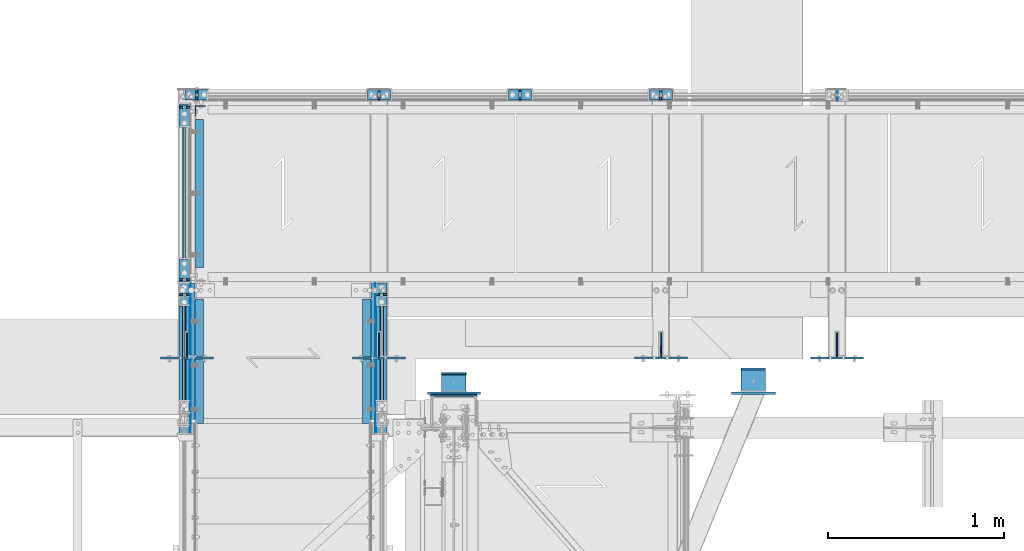
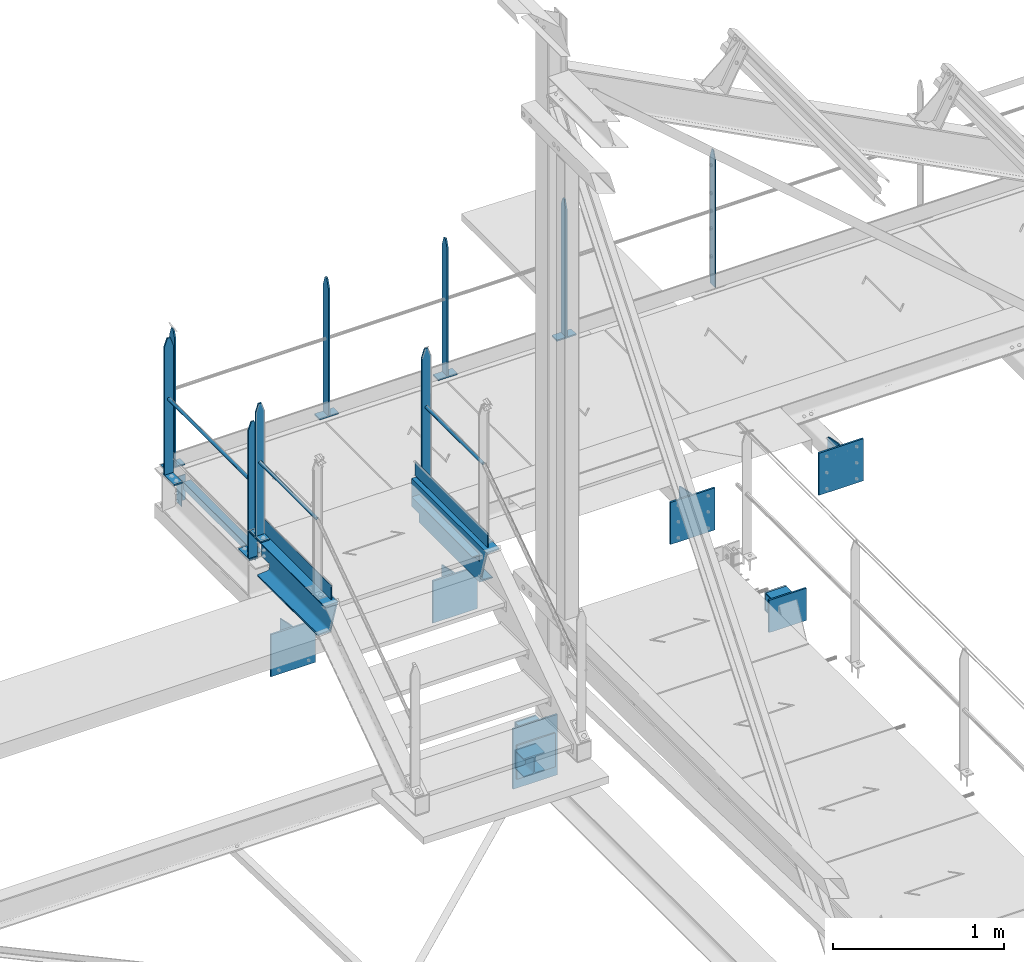
# One storey, part 95 of 496: 45 beams, 18 elements without a shape of their own.
"""IFC2X3 building model written with IfcOpenShell, lengths in millimetres."""

import ifcopenshell
import ifcopenshell.guid

model = None  # the IFC model being written
_history = None  # IfcOwnerHistory: only IFC2X3 demands one
_inside = {}  # id of a spatial element -> (the spatial element, [elements in it])
_under = {}  # id of a project, library or spatial element -> (it, [spatial elements below it])
_declared = {}  # id of a project -> (the project, [libraries it declares])
_typed = {}  # id of a type object -> (the type object, [elements of that type])
_made_of = {}  # id of a material, layer set ... -> (it, [elements and type objects made of it])


def new_model(schema):
    """Start an empty IFC model of exactly this schema.

    Asked for "IFC4X3", IfcOpenShell would pick the latest addendum, in which some entities
    have other attributes; the version numbers below select the first issue.
    IFC2X3 requires an IfcOwnerHistory on every rooted entity: one is made here for all.
    """
    global model, _history
    if schema == "IFC4X3":
        model = ifcopenshell.file(schema_version=(4, 3, 0, 0))
    else:
        model = ifcopenshell.file(schema=schema)
    _inside.clear()
    _under.clear()
    _declared.clear()
    _typed.clear()
    _made_of.clear()
    _history = None
    if model.schema == "IFC2X3":
        org = make("IfcOrganization", Name="unknown")
        user = make(
            "IfcPersonAndOrganization",
            ThePerson=make("IfcPerson", FamilyName="unknown"),
            TheOrganization=org,
        )
        app = make(
            "IfcApplication",
            ApplicationDeveloper=org,
            Version="unknown",
            ApplicationFullName="unknown",
            ApplicationIdentifier="unknown",
        )
        _history = make(
            "IfcOwnerHistory",
            OwningUser=user,
            OwningApplication=app,
            ChangeAction="ADDED",
            CreationDate=0,
        )
    return model


def make(cls, **values):
    """One entity of the class cls with the attributes given. An attribute that is None is left unset."""
    return model.create_entity(
        cls, **{name: value for name, value in values.items() if value is not None}
    )


def rooted(cls, **values):
    """An entity with a GlobalId (a new one), such as an element, a storey or a relation."""
    return make(cls, GlobalId=ifcopenshell.guid.new(), OwnerHistory=_history, **values)


def si_unit(unit_type, name, prefix=None):
    """IfcSIUnit, for example si_unit("LENGTHUNIT", "METRE", prefix="MILLI")."""
    return make("IfcSIUnit", UnitType=unit_type, Prefix=prefix, Name=name)


def assignment(units):
    """IfcUnitAssignment: the units of a project."""
    return None if units is None else make("IfcUnitAssignment", Units=units)


def point(xyz):
    """IfcCartesianPoint."""
    return None if xyz is None else make("IfcCartesianPoint", Coordinates=xyz)


def direction(xyz):
    """IfcDirection."""
    return None if xyz is None else make("IfcDirection", DirectionRatios=xyz)


def frame(location, z_axis=None, x_axis=None):
    """IfcAxis2Placement3D, a coordinate frame: its origin and axes. An axis left out is left unset."""
    return make(
        "IfcAxis2Placement3D",
        Location=point(location),
        Axis=direction(z_axis),
        RefDirection=direction(x_axis),
    )


def frame_2d(location, x_axis=None):
    """IfcAxis2Placement2D, a coordinate frame in the plane: its origin and x axis."""
    return make(
        "IfcAxis2Placement2D", Location=point(location), RefDirection=direction(x_axis)
    )


def origin_with_axes():
    """The frame at (0, 0, 0) with the z axis (0, 0, 1) and the x axis (1, 0, 0) written out."""
    return frame((0.0, 0.0, 0.0), z_axis=(0.0, 0.0, 1.0), x_axis=(1.0, 0.0, 0.0))


def origin_2d_with_axis():
    """The frame at (0, 0) in the plane with the x axis (1, 0) written out."""
    return frame_2d((0.0, 0.0), x_axis=(1.0, 0.0))


def place(relative_to, where):
    """IfcLocalPlacement: puts the frame where relative to a parent placement (None: the world)."""
    return make(
        "IfcLocalPlacement", PlacementRelTo=relative_to, RelativePlacement=where
    )


def context(
    kind, dimensions, precision=None, world=None, true_north=None, identifier=None
):
    """IfcGeometricRepresentationContext, for example the 3D "Model" context."""
    return make(
        "IfcGeometricRepresentationContext",
        ContextIdentifier=identifier,
        ContextType=kind,
        CoordinateSpaceDimension=dimensions,
        Precision=precision,
        WorldCoordinateSystem=world,
        TrueNorth=true_north,
    )


def subcontext(parent, identifier, kind, view, scale=None):
    """IfcGeometricRepresentationSubContext, for example "Body" below "Model"."""
    return make(
        "IfcGeometricRepresentationSubContext",
        ContextIdentifier=identifier,
        ContextType=kind,
        ParentContext=parent,
        TargetScale=scale,
        TargetView=view,
    )


def project(units=None, contexts=None):
    """IfcProject with its units and contexts."""
    return rooted(
        "IfcProject",
        Name="project",
        RepresentationContexts=contexts,
        UnitsInContext=assignment(units),
    )


def spatial(cls, under=None, at=None, **own):
    """A site, building, storey or space (cls), placed at a placement, below another one or the project."""
    s = rooted(cls, ObjectPlacement=at, **own)
    if under is not None:
        _under.setdefault(under.id(), (under, []))[1].append(s)
    return s


def polyline(points):
    """IfcPolyline through the points."""
    return make("IfcPolyline", Points=[point(p) for p in points])


def profile(cls, at=None, kind="AREA", **sizes):
    """A parametric profile (cls). Its sizes go by their IFC names, for example OverallWidth=200.0."""
    return make(cls, ProfileType=kind, Position=at, **sizes)


def rectangle(**sizes):
    """IfcRectangleProfileDef."""
    return profile("IfcRectangleProfileDef", **sizes)


def hollow_circle(**sizes):
    """IfcCircleHollowProfileDef."""
    return profile("IfcCircleHollowProfileDef", **sizes)


def i_section(**sizes):
    """IfcIShapeProfileDef."""
    return profile("IfcIShapeProfileDef", **sizes)


def l_section(**sizes):
    """IfcLShapeProfileDef."""
    return profile("IfcLShapeProfileDef", **sizes)


def u_section(**sizes):
    """IfcUShapeProfileDef."""
    return profile("IfcUShapeProfileDef", **sizes)


def outline(outer, holes=None, kind="AREA"):
    """IfcArbitraryClosedProfileDef: a profile drawn as a closed curve; with holes, ...WithVoids."""
    if holes is None:
        return make("IfcArbitraryClosedProfileDef", ProfileType=kind, OuterCurve=outer)
    return make(
        "IfcArbitraryProfileDefWithVoids",
        ProfileType=kind,
        OuterCurve=outer,
        InnerCurves=holes,
    )


def extrude(swept, where, along, depth):
    """IfcExtrudedAreaSolid: the profile swept, set in the frame where, extruded along a direction by depth."""
    return make(
        "IfcExtrudedAreaSolid",
        SweptArea=swept,
        Position=where,
        ExtrudedDirection=direction(along),
        Depth=depth,
    )


def boolean(op, a, b):
    """IfcBooleanResult of two solids."""
    return make("IfcBooleanResult", Operator=op, FirstOperand=a, SecondOperand=b)


def clip(a, b, op="DIFFERENCE"):
    """IfcBooleanClippingResult: the solid a cut by the half space b."""
    return make(
        "IfcBooleanClippingResult", Operator=op, FirstOperand=a, SecondOperand=b
    )


def halfspace(plane, agree):
    """IfcHalfSpaceSolid: all space on one side of the plane z = 0 of the frame plane."""
    return make(
        "IfcHalfSpaceSolid",
        BaseSurface=make("IfcPlane", Position=plane),
        AgreementFlag=agree,
    )


def shape(context_of_items, identifier, shape_type, items):
    """IfcShapeRepresentation: the items that make up one representation, for example the "Body"."""
    return make(
        "IfcShapeRepresentation",
        ContextOfItems=context_of_items,
        RepresentationIdentifier=identifier,
        RepresentationType=shape_type,
        Items=items,
    )


def material(Name=None, Category=None):
    """IfcMaterial."""
    return make("IfcMaterial", Name=Name, Category=Category)


def made_of(thing, what):
    """Note that an element or type object is made of a material, layer set ...; save() writes the relation."""
    if what is not None:
        _made_of.setdefault(what.id(), (what, []))[1].append(thing)
    return thing


def type_object(cls, material=None, **own):
    """A type object (cls), such as IfcWallType, which elements share."""
    return made_of(rooted(cls, **own), material)


def element(
    cls,
    number,
    at=None,
    inside=None,
    cuts=None,
    type_object=None,
    material=None,
    context=None,
    identifier="Body",
    shape_type=None,
    held_by="IfcProductDefinitionShape",
    body=None,
    shapes=None,
    **own,
):
    """One element of the class cls, such as IfcWall. Its Tag is "e" and its number.

    at: its placement. inside: the storey or other place that contains it. cuts: it is an
    opening in that element (IfcRelVoidsElement). A single representation is given by context,
    identifier, shape_type and body (its items); several are given by shapes. held_by: the class
    of the entity that holds the representations. save() writes the other relations.
    """
    e = rooted(cls, Tag="e%d" % number, ObjectPlacement=at, **own)
    if body is not None:
        shapes = [shape(context, identifier, shape_type, body)]
    if shapes is not None:
        e.Representation = make(held_by, Representations=shapes)
    if inside is not None:
        _inside.setdefault(inside.id(), (inside, []))[1].append(e)
    if cuts is not None:
        rooted(
            "IfcRelVoidsElement", RelatingBuildingElement=cuts, RelatedOpeningElement=e
        )
    if type_object is not None:
        _typed.setdefault(type_object.id(), (type_object, []))[1].append(e)
    return made_of(e, material)


def aggregate(whole, parts):
    """IfcRelAggregates: a whole, such as a stair, and the parts it consists of."""
    return rooted("IfcRelAggregates", RelatingObject=whole, RelatedObjects=parts)


def save(model, path):
    """Write the relations noted so far, then the file.

    IfcRelAggregates (storeys below a building ...), IfcRelContainedInSpatialStructure (elements
    in a storey), IfcRelDefinesByType, IfcRelAssociatesMaterial and IfcRelDeclares: one each for
    every whole, place, type object, material and project.
    """
    for whole, parts in _under.values():
        aggregate(whole, parts)
    for where, things in _inside.values():
        rooted(
            "IfcRelContainedInSpatialStructure",
            RelatedElements=things,
            RelatingStructure=where,
        )
    for kind, things in _typed.values():
        rooted("IfcRelDefinesByType", RelatedObjects=things, RelatingType=kind)
    for what, things in _made_of.values():
        rooted("IfcRelAssociatesMaterial", RelatedObjects=things, RelatingMaterial=what)
    for by, libraries in _declared.values():
        rooted("IfcRelDeclares", RelatingContext=by, RelatedDefinitions=libraries)
    model.write(path)


model = new_model("IFC2X3")

# Units and contexts
model_context = context("Model", 3, precision=1e-05, world=origin_with_axes())
body_context = subcontext(model_context, "Body", "Model", "MODEL_VIEW")
ifc_project = project(units=[si_unit("LENGTHUNIT", "METRE", prefix="MILLI"), si_unit("AREAUNIT", "SQUARE_METRE"), si_unit("VOLUMEUNIT", "CUBIC_METRE"), si_unit("MASSUNIT", "GRAM", prefix="KILO"), si_unit("TIMEUNIT", "SECOND"), si_unit("PLANEANGLEUNIT", "RADIAN"), si_unit("SOLIDANGLEUNIT", "STERADIAN"), si_unit("THERMODYNAMICTEMPERATUREUNIT", "DEGREE_CELSIUS"), si_unit("LUMINOUSINTENSITYUNIT", "LUMEN")], contexts=[model_context])

# Site, building, storey
site_placement = place(None, origin_with_axes())
site = spatial("IfcSite", under=ifc_project, at=site_placement, CompositionType="ELEMENT")
building_placement = place(site_placement, origin_with_axes())
building = spatial("IfcBuilding", under=site, at=building_placement, Name="Undefined", CompositionType="ELEMENT")
storey_placement = place(building_placement, origin_with_axes())
storey = spatial("IfcBuildingStorey", under=building, at=storey_placement, Name="Undefined", CompositionType="ELEMENT", Elevation=0.0)

# Assembly, beams
assembly_1_placement = place(storey_placement, origin_with_axes())
assembly_1 = element("IfcElementAssembly", 1, at=assembly_1_placement, inside=storey, Name="MAIN COURANTE", AssemblyPlace="NOTDEFINED", PredefinedType="NOTDEFINED")
ifc_material_1 = material(Name="Undefined/S235-E24")
beam_type_1 = type_object("IfcBeamType", PredefinedType="NOTDEFINED")
beam_1_placement = place(assembly_1_placement, frame((13119.9961849193, 17089.9938659712, 8705.00000001012), z_axis=(0.0, 1.0, 0.0), x_axis=(-1.0, 0.0, 0.0)))
beam_1 = element("IfcBeam", 2, at=beam_1_placement, type_object=beam_type_1, material=ifc_material_1, context=body_context, shape_type="SweptSolid", body=[
    extrude(rectangle(XDim=10.0, YDim=60.0, at=origin_2d_with_axis()), frame((130.0, 0.0, 0.0), z_axis=(-1.0, 0.0, 0.0), x_axis=(0.0, -1.0, 0.0)), (0.0, 0.0, 1.0), 130.0),
])
beam_2_placement = place(assembly_1_placement, frame((13054.9961849193, 17089.9938659712, 9677.59999847), z_axis=(0.0, -1.0, 0.0), x_axis=(0.0, 0.0, -1.0)))
beam_2 = element("IfcBeam", 3, at=beam_2_placement, type_object=beam_type_1, material=ifc_material_1, Name="MONTANT", context=body_context, shape_type="Clipping", body=[
    clip(clip(extrude(rectangle(XDim=10.0, YDim=60.0, at=origin_2d_with_axis()), frame((967.59999845988, 0.0, 0.0), z_axis=(-1.0, 0.0, 0.0), x_axis=(0.0, -1.0, 0.0)), (0.0, 0.0, 1.0), 967.6), halfspace(frame((-120.0, 5.0, -30.0), z_axis=(-0.316227766016838, 0.0, 0.948683298050514), x_axis=(0.948683298050514, 0.0, 0.316227766016838)), False)), halfspace(frame((60.0, 5.0, -30.0), z_axis=(-0.316227766016838, 0.0, -0.948683298050514), x_axis=(-0.948683298050514, 0.0, 0.316227766016838)), False)),
])
beam_3_placement = place(assembly_1_placement, frame((13919.9961849193, 17089.9938659712, 8705.00000001012), z_axis=(0.0, 1.0, 0.0), x_axis=(-1.0, 0.0, 0.0)))
beam_3 = element("IfcBeam", 4, at=beam_3_placement, type_object=beam_type_1, material=ifc_material_1, context=body_context, shape_type="SweptSolid", body=[
    extrude(rectangle(XDim=10.0, YDim=60.0, at=origin_2d_with_axis()), frame((130.0, 0.0, 0.0), z_axis=(-1.0, 0.0, 0.0), x_axis=(0.0, -1.0, 0.0)), (0.0, 0.0, 1.0), 130.0),
])
beam_4_placement = place(assembly_1_placement, frame((11285.0061849211, 17089.9938659712, 8705.00001258772), z_axis=(0.0, 1.0, 0.0), x_axis=(-1.0, 0.0, 0.0)))
beam_4 = element("IfcBeam", 5, at=beam_4_placement, type_object=beam_type_1, material=ifc_material_1, context=body_context, shape_type="SweptSolid", body=[
    extrude(rectangle(XDim=10.0, YDim=60.0, at=origin_2d_with_axis()), frame((130.0, 0.0, 0.0), z_axis=(-1.0, 0.0, 0.0), x_axis=(0.0, -1.0, 0.0)), (0.0, 0.0, 1.0), 130.0),
])
beam_5_placement = place(assembly_1_placement, frame((11220.0061849211, 17089.9938659712, 9677.6000110476), z_axis=(0.0, -1.0, 0.0), x_axis=(0.0, 0.0, -1.0)))
beam_5 = element("IfcBeam", 6, at=beam_5_placement, type_object=beam_type_1, material=ifc_material_1, Name="MONTANT", context=body_context, shape_type="Clipping", body=[
    clip(clip(extrude(rectangle(XDim=10.0, YDim=60.0, at=origin_2d_with_axis()), frame((967.59999845988, 0.0, 0.0), z_axis=(-1.0, 0.0, 0.0), x_axis=(0.0, -1.0, 0.0)), (0.0, 0.0, 1.0), 967.6), halfspace(frame((-120.0, 5.0, -30.0), z_axis=(-0.316227766016838, 0.0, 0.948683298050514), x_axis=(0.948683298050514, 0.0, 0.316227766016838)), False)), halfspace(frame((60.0, 5.0, -30.0), z_axis=(-0.316227766016838, 0.0, -0.948683298050514), x_axis=(-0.948683298050514, 0.0, 0.316227766016838)), False)),
])
beam_6_placement = place(assembly_1_placement, frame((12319.9961849193, 17089.9938659712, 8705.00000001012), z_axis=(0.0, 1.0, 0.0), x_axis=(-1.0, 0.0, 0.0)))
beam_6 = element("IfcBeam", 7, at=beam_6_placement, type_object=beam_type_1, material=ifc_material_1, context=body_context, shape_type="SweptSolid", body=[
    extrude(rectangle(XDim=10.0, YDim=60.0, at=origin_2d_with_axis()), frame((130.0, 0.0, 0.0), z_axis=(-1.0, 0.0, 0.0), x_axis=(0.0, -1.0, 0.0)), (0.0, 0.0, 1.0), 130.0),
])

assembly_2_placement = place(storey_placement, origin_with_axes())
assembly_2 = element("IfcElementAssembly", 8, at=assembly_2_placement, inside=storey, Name="MAIN COURANTE", AssemblyPlace="NOTDEFINED", PredefinedType="NOTDEFINED")
beam_7_placement = place(assembly_2_placement, frame((11149.9863365012, 16155.0036560214, 8705.00000001012), z_axis=(-1.0, 0.0, 0.0), x_axis=(0.0, -1.0, 0.0)))
beam_7 = element("IfcBeam", 9, at=beam_7_placement, type_object=beam_type_1, material=ifc_material_1, context=body_context, shape_type="SweptSolid", body=[
    extrude(rectangle(XDim=10.0, YDim=60.0, at=origin_2d_with_axis()), frame((130.0, 0.0, 0.0), z_axis=(-1.0, 0.0, 0.0), x_axis=(0.0, -1.0, 0.0)), (0.0, 0.0, 1.0), 130.0),
])
beam_8_placement = place(assembly_2_placement, frame((11149.9862112009, 16040.0036560214, 9677.59999848012), z_axis=(-0.99999999999782, -2.08799998896818e-06, 0.0), x_axis=(0.0, 0.0, -1.0)))
beam_8 = element("IfcBeam", 10, at=beam_8_placement, type_object=beam_type_1, material=ifc_material_1, Name="MONTANT", context=body_context, shape_type="Clipping", body=[
    clip(clip(extrude(rectangle(XDim=10.0, YDim=60.0, at=origin_2d_with_axis()), frame((967.59999845988, 0.0, 0.0), z_axis=(-1.0, 0.0, 0.0), x_axis=(0.0, -1.0, 0.0)), (0.0, 0.0, 1.0), 967.6), halfspace(frame((-119.999937359999, -4.99999999999636, -30.0), z_axis=(-0.316227766016837, -1.98085072276202e-06, 0.948683298048446), x_axis=(-6.26399999950979e-06, 0.999999999980381, -3.63797880701241e-15)), False)), halfspace(frame((60.0, -5.0, -30.0), z_axis=(-0.316227469016822, 1.98084886235393e-06, -0.948683397048399), x_axis=(6.26399999950979e-06, 0.999999999980381, -3.63797880701241e-15)), False)),
])
beam_9_placement = place(assembly_2_placement, frame((11149.9863365012, 17034.9977309424, 8705.00000001012), z_axis=(-1.0, 0.0, 0.0), x_axis=(0.0, -1.0, 0.0)))
beam_9 = element("IfcBeam", 11, at=beam_9_placement, type_object=beam_type_1, material=ifc_material_1, context=body_context, shape_type="SweptSolid", body=[
    extrude(rectangle(XDim=10.0, YDim=60.0, at=origin_2d_with_axis()), frame((130.0, 0.0, 0.0), z_axis=(-1.0, 0.0, 0.0), x_axis=(0.0, -1.0, 0.0)), (0.0, 0.0, 1.0), 130.0),
])
beam_10_placement = place(assembly_2_placement, frame((11149.9862112009, 17019.9977309424, 9677.59999848012), z_axis=(-0.99999999999782, -2.08799998896818e-06, 0.0), x_axis=(0.0, 0.0, -1.0)))
beam_10 = element("IfcBeam", 12, at=beam_10_placement, type_object=beam_type_1, material=ifc_material_1, Name="MONTANT", context=body_context, shape_type="Clipping", body=[
    clip(clip(extrude(rectangle(XDim=10.0, YDim=60.0, at=origin_2d_with_axis()), frame((967.59999845988, 0.0, 0.0), z_axis=(-1.0, 0.0, 0.0), x_axis=(0.0, -1.0, 0.0)), (0.0, 0.0, 1.0), 967.6), halfspace(frame((-119.999937359999, -4.99999999999636, -30.0), z_axis=(-0.316227766016837, -1.98085072276202e-06, 0.948683298048446), x_axis=(-6.26399999950979e-06, 0.999999999980381, -3.63797880701241e-15)), False)), halfspace(frame((60.0, -5.0, -30.0), z_axis=(-0.316227469016822, 1.98084886235393e-06, -0.948683397048399), x_axis=(6.26399999950979e-06, 0.999999999980381, -3.63797880701241e-15)), False)),
])

# Beam
beam_11_placement = place(assembly_1_placement, frame((13854.9961849193, 17089.9938659712, 9677.59999847), z_axis=(0.0, -1.0, 0.0), x_axis=(0.0, 0.0, -1.0)))
beam_11 = element("IfcBeam", 13, at=beam_11_placement, type_object=beam_type_1, material=ifc_material_1, Name="MONTANT", context=body_context, shape_type="Clipping", body=[
    clip(clip(extrude(rectangle(XDim=10.0, YDim=60.0, at=origin_2d_with_axis()), frame((967.59999845988, 0.0, 0.0), z_axis=(-1.0, 0.0, 0.0), x_axis=(0.0, -1.0, 0.0)), (0.0, 0.0, 1.0), 967.6), halfspace(frame((-120.0, 5.0, -30.0), z_axis=(-0.316227766016838, 0.0, 0.948683298050514), x_axis=(0.948683298050514, 0.0, 0.316227766016838)), False)), halfspace(frame((60.0, 5.0, -30.0), z_axis=(-0.316227766016838, 0.0, -0.948683298050514), x_axis=(-0.948683298050514, 0.0, 0.316227766016838)), False)),
])

beam_12_placement = place(assembly_1_placement, frame((12254.9961849193, 17089.9938659712, 9677.59999847), z_axis=(0.0, -1.0, 0.0), x_axis=(0.0, 0.0, -1.0)))
beam_12 = element("IfcBeam", 14, at=beam_12_placement, type_object=beam_type_1, material=ifc_material_1, Name="MONTANT", context=body_context, shape_type="Clipping", body=[
    clip(clip(extrude(rectangle(XDim=10.0, YDim=60.0, at=origin_2d_with_axis()), frame((967.59999845988, 0.0, 0.0), z_axis=(-1.0, 0.0, 0.0), x_axis=(0.0, -1.0, 0.0)), (0.0, 0.0, 1.0), 967.6), halfspace(frame((-120.0, 5.0, -30.0), z_axis=(-0.316227766016838, 0.0, 0.948683298050514), x_axis=(0.948683298050514, 0.0, 0.316227766016838)), False)), halfspace(frame((60.0, 5.0, -30.0), z_axis=(-0.316227766016838, 0.0, -0.948683298050514), x_axis=(-0.948683298050514, 0.0, 0.316227766016838)), False)),
])

aggregate(assembly_1, [beam_1, beam_2, beam_3, beam_4, beam_5, beam_6, beam_11, beam_12])

# Assembly, beams
assembly_3_placement = place(storey_placement, origin_with_axes())
assembly_3 = element("IfcElementAssembly", 15, at=assembly_3_placement, inside=storey, Name="MAIN COURANTE", AssemblyPlace="NOTDEFINED", PredefinedType="NOTDEFINED")
beam_13_placement = place(assembly_3_placement, frame((11149.9863365012, 16019.9996531834, 8915.0), z_axis=(-1.0, 0.0, 0.0), x_axis=(0.0, -1.0, 0.0)))
beam_13 = element("IfcBeam", 16, at=beam_13_placement, type_object=beam_type_1, material=ifc_material_1, context=body_context, shape_type="SweptSolid", body=[
    extrude(rectangle(XDim=10.0, YDim=60.0, at=origin_2d_with_axis()), frame((130.0, 0.0, 0.0), z_axis=(-1.0, 0.0, 0.0), x_axis=(0.0, -1.0, 0.0)), (0.0, 0.0, 1.0), 130.0),
])
beam_14_placement = place(assembly_3_placement, frame((11149.9862112009, 15954.9996531834, 9857.59999847), z_axis=(-0.99999999999782, -2.08799998896818e-06, 0.0), x_axis=(0.0, 0.0, -1.0)))
beam_14 = element("IfcBeam", 17, at=beam_14_placement, type_object=beam_type_1, material=ifc_material_1, Name="MONTANT", context=body_context, shape_type="Clipping", body=[
    clip(clip(extrude(rectangle(XDim=10.0, YDim=60.0, at=origin_2d_with_axis()), frame((937.599998469999, 0.0, 0.0), z_axis=(-1.0, 0.0, 0.0), x_axis=(0.0, -1.0, 0.0)), (0.0, 0.0, 1.0), 937.6), halfspace(frame((-119.999937359999, -4.99999999999636, -30.0), z_axis=(-0.316227766016837, -1.98085072276202e-06, 0.948683298048446), x_axis=(-6.26399999950979e-06, 0.999999999980381, -3.63797880701241e-15)), False)), halfspace(frame((60.0, -5.0, -30.0), z_axis=(-0.316227469016822, 1.98084886235393e-06, -0.948683397048399), x_axis=(6.26399999950979e-06, 0.999999999980381, -3.63797880701241e-15)), False)),
])

assembly_4_placement = place(storey_placement, origin_with_axes())
assembly_4 = element("IfcElementAssembly", 18, at=assembly_4_placement, inside=storey, Name="MAIN COURANTE", AssemblyPlace="NOTDEFINED", PredefinedType="NOTDEFINED")
beam_15_placement = place(assembly_4_placement, frame((12269.9936634988, 16019.9996531834, 8915.0), z_axis=(1.0, 0.0, 0.0), x_axis=(0.0, -1.0, 0.0)))
beam_15 = element("IfcBeam", 19, at=beam_15_placement, type_object=beam_type_1, material=ifc_material_1, context=body_context, shape_type="SweptSolid", body=[
    extrude(rectangle(XDim=10.0, YDim=60.0, at=origin_2d_with_axis()), frame((130.0, 0.0, 0.0), z_axis=(-1.0, 0.0, 0.0), x_axis=(0.0, -1.0, 0.0)), (0.0, 0.0, 1.0), 130.0),
])
beam_16_placement = place(assembly_4_placement, frame((12269.9937887991, 15954.9996531834, 9857.59999847), z_axis=(0.999999999998558, -1.69800000185205e-06, 0.0), x_axis=(0.0, 0.0, -1.0)))
beam_16 = element("IfcBeam", 20, at=beam_16_placement, type_object=beam_type_1, material=ifc_material_1, Name="MONTANT", context=body_context, shape_type="Clipping", body=[
    clip(clip(extrude(rectangle(XDim=10.0, YDim=60.0, at=origin_2d_with_axis()), frame((937.599998469999, 0.0, 0.0), z_axis=(-1.0, 0.0, 0.0), x_axis=(0.0, -1.0, 0.0)), (0.0, 0.0, 1.0), 937.6), halfspace(frame((-119.999937359999, 4.99999999999818, -30.0), z_axis=(-0.316227766016843, 1.98085072621335e-06, 0.948683298048444), x_axis=(0.948683298050514, 0.0, 0.316227766016838)), False)), halfspace(frame((60.0, 5.0, -30.0), z_axis=(-0.316227469016822, -1.98084886580522e-06, -0.948683397048399), x_axis=(-0.948683298050514, 0.0, 0.316227766016838)), False)),
])
beam_type_2 = type_object("IfcBeamType", PredefinedType="NOTDEFINED")
beam_17_placement = place(assembly_4_placement, frame((12269.9936634988, 15290.0038659711, 9438.8), z_axis=(0.999999999998558, -1.69800000185205e-06, 0.0), x_axis=(1.69800000215235e-06, 0.999999999998558, 0.0)))
beam_17 = element("IfcBeam", 21, at=beam_17_placement, type_object=beam_type_2, material=ifc_material_1, Name="LISSE", context=body_context, shape_type="SweptSolid", body=[
    extrude(hollow_circle(Radius=10.64999962, WallThickness=2.0, at=origin_2d_with_axis()), frame((659.995802516527, 1.81898940354586e-12, -1.3975954744526e-19), z_axis=(-1.0, 0.0, 0.0), x_axis=(0.0, -1.0, 0.0)), (0.0, 0.0, 1.0), 660.0),
])

# Beam
beam_18_placement = place(assembly_2_placement, frame((11149.9863365012, 16045.0036560216, 9243.80000001012), z_axis=(-0.99999999999782, -2.08799998896818e-06, 0.0), x_axis=(-1.15500000027281e-06, 0.999999999999333, 0.0)))
beam_18 = element("IfcBeam", 22, at=beam_18_placement, type_object=beam_type_2, material=ifc_material_1, Name="LISSE", context=body_context, shape_type="SweptSolid", body=[
    extrude(hollow_circle(Radius=10.64999962, WallThickness=2.0, at=origin_2d_with_axis()), frame((969.994074923011, -1.81898940354586e-12, 0.0), z_axis=(-1.0, 0.0, 0.0), x_axis=(0.0, -1.0, 0.0)), (0.0, 0.0, 1.0), 969.99),
])

aggregate(assembly_2, [beam_7, beam_8, beam_18, beam_9, beam_10])

beam_19_placement = place(assembly_3_placement, frame((11149.9863365012, 15290.0038659711, 9438.8), z_axis=(-0.99999999999782, -2.08799998896818e-06, 0.0), x_axis=(-1.15500000027281e-06, 0.999999999999333, 0.0)))
beam_19 = element("IfcBeam", 23, at=beam_19_placement, type_object=beam_type_2, material=ifc_material_1, Name="LISSE", context=body_context, shape_type="SweptSolid", body=[
    extrude(hollow_circle(Radius=10.64999962, WallThickness=2.0, at=origin_2d_with_axis()), frame((659.996492836223, -1.81898940354586e-12, 0.0), z_axis=(-1.0, 0.0, 0.0), x_axis=(0.0, -1.0, 0.0)), (0.0, 0.0, 1.0), 660.0),
])

# Assembly, beam
assembly_5_placement = place(storey_placement, origin_with_axes())
assembly_5 = element("IfcElementAssembly", 24, at=assembly_5_placement, inside=storey, Name="CONSOLE", AssemblyPlace="NOTDEFINED", PredefinedType="NOTDEFINED")
beam_type_3 = type_object("IfcBeamType", PredefinedType="NOTDEFINED")
beam_20_placement = place(assembly_5_placement, frame((12255.0007605158, 15622.0, 8175.0), z_axis=(-1.0, 0.0, 0.0), x_axis=(0.0, -1.0, 0.0)))
beam_20 = element("IfcBeam", 25, at=beam_20_placement, type_object=beam_type_3, material=ifc_material_1, Name="CONSOLE", context=body_context, shape_type="SweptSolid", body=[
    extrude(outline(polyline([(0.0, 0.0), (20.0, 0.0), (20.0, 300.0), (0.0, 300.0), (-118.0, 275.0), (-118.0, 155.0), (0.0, 0.0)])), frame((0.0, 0.0, -4.0), z_axis=(0.0, 0.0, 1.0), x_axis=(1.0, 0.0, 0.0)), (0.0, 0.0, 1.0), 8.0),
])

assembly_6_placement = place(storey_placement, origin_with_axes())
assembly_6 = element("IfcElementAssembly", 26, at=assembly_6_placement, inside=storey, Name="CONSOLE", AssemblyPlace="NOTDEFINED", PredefinedType="NOTDEFINED")
beam_21_placement = place(assembly_6_placement, frame((14855.0007605158, 15622.0, 8175.0), z_axis=(-1.0, 0.0, 0.0), x_axis=(0.0, -1.0, 0.0)))
beam_21 = element("IfcBeam", 27, at=beam_21_placement, type_object=beam_type_3, material=ifc_material_1, Name="CONSOLE", context=body_context, shape_type="SweptSolid", body=[
    extrude(outline(polyline([(0.0, 0.0), (20.0, 0.0), (20.0, 300.0), (0.0, 300.0), (-118.0, 275.0), (-118.0, 155.0), (0.0, 0.0)])), frame((0.0, 0.0, -4.0), z_axis=(0.0, 0.0, 1.0), x_axis=(1.0, 0.0, 0.0)), (0.0, 0.0, 1.0), 8.0),
])

assembly_7_placement = place(storey_placement, origin_with_axes())
assembly_7 = element("IfcElementAssembly", 28, at=assembly_7_placement, inside=storey, Name="CONSOLE", AssemblyPlace="NOTDEFINED", PredefinedType="NOTDEFINED")
beam_22_placement = place(assembly_7_placement, frame((13855.0007605158, 15622.0, 8175.0), z_axis=(-1.0, 0.0, 0.0), x_axis=(0.0, -1.0, 0.0)))
beam_22 = element("IfcBeam", 29, at=beam_22_placement, type_object=beam_type_3, material=ifc_material_1, Name="CONSOLE", context=body_context, shape_type="SweptSolid", body=[
    extrude(outline(polyline([(0.0, 0.0), (20.0, 0.0), (20.0, 300.0), (0.0, 300.0), (-118.0, 275.0), (-118.0, 155.0), (0.0, 0.0)])), frame((0.0, 0.0, -4.0), z_axis=(0.0, 0.0, 1.0), x_axis=(1.0, 0.0, 0.0)), (0.0, 0.0, 1.0), 8.0),
])

assembly_8_placement = place(storey_placement, origin_with_axes())
assembly_8 = element("IfcElementAssembly", 30, at=assembly_8_placement, inside=storey, Name="CONSOLE", AssemblyPlace="NOTDEFINED", PredefinedType="NOTDEFINED")
beam_23_placement = place(assembly_8_placement, frame((11165.0007605157, 15622.0, 8175.0), z_axis=(-1.0, 0.0, 0.0), x_axis=(0.0, -1.0, 0.0)))
beam_23 = element("IfcBeam", 31, at=beam_23_placement, type_object=beam_type_3, material=ifc_material_1, Name="CONSOLE", context=body_context, shape_type="SweptSolid", body=[
    extrude(outline(polyline([(0.0, 0.0), (20.0, 0.0), (20.0, 300.0), (0.0, 300.0), (-118.0, 275.0), (-118.0, 155.0), (0.0, 0.0)])), frame((0.0, 0.0, -4.0), z_axis=(0.0, 0.0, 1.0), x_axis=(1.0, 0.0, 0.0)), (0.0, 0.0, 1.0), 8.0),
])

# Beam
beam_type_4 = type_object("IfcBeamType", PredefinedType="NOTDEFINED")
beam_24_placement = place(assembly_5_placement, frame((12255.0007605158, 15595.99984642, 8475.0), z_axis=(1.0, 0.0, 0.0), x_axis=(0.0, 0.0, -1.0)))
beam_24 = element("IfcBeam", 32, at=beam_24_placement, type_object=beam_type_4, material=ifc_material_1, Name="CONSOLE", context=body_context, shape_type="SweptSolid", body=[
    extrude(rectangle(XDim=12.0, YDim=300.0, at=origin_2d_with_axis()), frame((300.0, 0.0, 0.0), z_axis=(-1.0, 0.0, 0.0), x_axis=(0.0, -1.0, 0.0)), (0.0, 0.0, 1.0), 300.0),
])

aggregate(assembly_5, [beam_20, beam_24])

beam_25_placement = place(assembly_6_placement, frame((14855.0007605158, 15595.99984642, 8475.0), z_axis=(1.0, 0.0, 0.0), x_axis=(0.0, 0.0, -1.0)))
beam_25 = element("IfcBeam", 33, at=beam_25_placement, type_object=beam_type_4, material=ifc_material_1, Name="CONSOLE", context=body_context, shape_type="SweptSolid", body=[
    extrude(rectangle(XDim=12.0, YDim=300.0, at=origin_2d_with_axis()), frame((300.0, 0.0, 0.0), z_axis=(-1.0, 0.0, 0.0), x_axis=(0.0, -1.0, 0.0)), (0.0, 0.0, 1.0), 300.0),
])

aggregate(assembly_6, [beam_21, beam_25])

beam_26_placement = place(assembly_7_placement, frame((13855.0007605158, 15595.99984642, 8475.0), z_axis=(1.0, 0.0, 0.0), x_axis=(0.0, 0.0, -1.0)))
beam_26 = element("IfcBeam", 34, at=beam_26_placement, type_object=beam_type_4, material=ifc_material_1, Name="CONSOLE", context=body_context, shape_type="SweptSolid", body=[
    extrude(rectangle(XDim=12.0, YDim=300.0, at=origin_2d_with_axis()), frame((300.0, 0.0, 0.0), z_axis=(-1.0, 0.0, 0.0), x_axis=(0.0, -1.0, 0.0)), (0.0, 0.0, 1.0), 300.0),
])

aggregate(assembly_7, [beam_22, beam_26])

beam_27_placement = place(assembly_8_placement, frame((11165.0007605157, 15596.0, 8475.0), z_axis=(1.0, 0.0, 0.0), x_axis=(0.0, 0.0, -1.0)))
beam_27 = element("IfcBeam", 35, at=beam_27_placement, type_object=beam_type_4, material=ifc_material_1, Name="CONSOLE", context=body_context, shape_type="SweptSolid", body=[
    extrude(rectangle(XDim=12.0, YDim=300.0, at=origin_2d_with_axis()), frame((300.0, 0.0, 0.0), z_axis=(-1.0, 0.0, 0.0), x_axis=(0.0, -1.0, 0.0)), (0.0, 0.0, 1.0), 300.0),
])

aggregate(assembly_8, [beam_23, beam_27])

# Assembly, beam
assembly_9_placement = place(storey_placement, origin_with_axes())
assembly_9 = element("IfcElementAssembly", 36, at=assembly_9_placement, inside=storey, AssemblyPlace="NOTDEFINED", PredefinedType="NOTDEFINED")
beam_28_placement = place(assembly_9_placement, frame((12680.0000000259, 15395.9999998312, 7394.99830350895), z_axis=(-1.0, 0.0, 0.0), x_axis=(0.0, 0.0, -1.0)))
beam_28 = element("IfcBeam", 37, at=beam_28_placement, type_object=beam_type_4, material=ifc_material_1, context=body_context, shape_type="SweptSolid", body=[
    extrude(rectangle(XDim=12.0, YDim=300.0, at=origin_2d_with_axis()), frame((429.999999999754, 0.0, 0.0), z_axis=(-1.0, 0.0, 0.0), x_axis=(0.0, -1.0, 0.0)), (0.0, 0.0, 1.0), 430.0),
])

# Beam
beam_type_5 = type_object("IfcBeamType", PredefinedType="NOTDEFINED")
beam_29_placement = place(assembly_3_placement, frame((11182.4987221813, 16020.0003588078, 8970.0), z_axis=(0.0, 0.0, -1.0), x_axis=(0.0, -1.0, 0.0)))
beam_29 = element("IfcBeam", 38, at=beam_29_placement, type_object=beam_type_5, material=ifc_material_1, context=body_context, shape_type="SweptSolid", body=[
    extrude(rectangle(XDim=5.0, YDim=100.0, at=origin_2d_with_axis()), frame((845.000567757703, 0.0, 0.0), z_axis=(-1.0, 0.0, 0.0), x_axis=(0.0, -1.0, 0.0)), (0.0, 0.0, 1.0), 845.0),
])

aggregate(assembly_3, [beam_19, beam_29, beam_13, beam_14])

beam_30_placement = place(assembly_4_placement, frame((12237.4812778187, 16019.9996531834, 8970.0), z_axis=(0.0, 0.0, -1.0), x_axis=(0.0, -1.0, 0.0)))
beam_30 = element("IfcBeam", 39, at=beam_30_placement, type_object=beam_type_5, material=ifc_material_1, context=body_context, shape_type="SweptSolid", body=[
    extrude(rectangle(XDim=5.0, YDim=100.0, at=origin_2d_with_axis()), frame((844.999862133349, 0.0, 0.0), z_axis=(-1.0, 0.0, 0.0), x_axis=(0.0, -1.0, 0.0)), (0.0, 0.0, 1.0), 845.0),
])

aggregate(assembly_4, [beam_17, beam_30, beam_15, beam_16])

# Assembly, beam
assembly_10_placement = place(storey_placement, origin_with_axes())
assembly_10 = element("IfcElementAssembly", 40, at=assembly_10_placement, inside=storey, Name="MAIN COURANTE", AssemblyPlace="NOTDEFINED", PredefinedType="NOTDEFINED")
beam_type_6 = type_object("IfcBeamType", PredefinedType="NOTDEFINED")
beam_31_placement = place(assembly_10_placement, frame((14857.4961849229, 17089.9938659712, 9677.59999847), z_axis=(0.0, -1.0, 0.0), x_axis=(0.0, 0.0, -1.0)))
beam_31 = element("IfcBeam", 41, at=beam_31_placement, type_object=beam_type_6, material=ifc_material_1, Name="MONTANT", context=body_context, shape_type="Clipping", body=[
    clip(clip(extrude(rectangle(XDim=5.0, YDim=60.0, at=origin_2d_with_axis()), frame((967.59999845988, 0.0, 0.0), z_axis=(-1.0, 0.0, 0.0), x_axis=(0.0, -1.0, 0.0)), (0.0, 0.0, 1.0), 967.6), halfspace(frame((-120.0, -5.0, -30.0), z_axis=(-0.316227766016838, 0.0, 0.948683298050514), x_axis=(0.0, 1.0, 0.0)), False)), halfspace(frame((60.0, -5.0, -30.0), z_axis=(-0.316227766016838, 0.0, -0.948683298050514), x_axis=(0.0, 1.0, 0.0)), False)),
])
aggregate(assembly_10, [beam_31])

assembly_11_placement = place(storey_placement, origin_with_axes())
assembly_11 = element("IfcElementAssembly", 42, at=assembly_11_placement, inside=storey, Name="SUPPORT", AssemblyPlace="NOTDEFINED", PredefinedType="NOTDEFINED")
beam_type_7 = type_object("IfcBeamType", PredefinedType="NOTDEFINED")
beam_32_placement = place(assembly_11_placement, frame((12184.9814327271, 15930.0058468547, 8825.0), z_axis=(-1.0, 0.0, 0.0), x_axis=(0.0, -1.0, 0.0)))
beam_32 = element("IfcBeam", 43, at=beam_32_placement, type_object=beam_type_7, material=ifc_material_1, Name="SUPPORT", context=body_context, shape_type="SweptSolid", body=[
    extrude(l_section(Depth=50.0, Width=50.0, Thickness=5.0, FilletRadius=7.0, EdgeRadius=3.5, at=origin_2d_with_axis()), frame((704.999999999984, 0.0, 0.0), z_axis=(-1.0, 0.0, 0.0), x_axis=(0.0, -1.0, 0.0)), (0.0, 0.0, 1.0), 705.0),
])
aggregate(assembly_11, [beam_32])

assembly_12_placement = place(storey_placement, origin_with_axes())
assembly_12 = element("IfcElementAssembly", 44, at=assembly_12_placement, inside=storey, Name="SUPPORT", AssemblyPlace="NOTDEFINED", PredefinedType="NOTDEFINED")
beam_33_placement = place(assembly_12_placement, frame((11235.0061849613, 15225.0058468548, 8825.0), z_axis=(1.0, 0.0, 0.0), x_axis=(0.0, 1.0, 0.0)))
beam_33 = element("IfcBeam", 45, at=beam_33_placement, type_object=beam_type_7, material=ifc_material_1, Name="SUPPORT", context=body_context, shape_type="SweptSolid", body=[
    extrude(l_section(Depth=50.0, Width=50.0, Thickness=5.0, FilletRadius=7.0, EdgeRadius=3.5, at=origin_2d_with_axis()), frame((704.999999999984, 0.0, 0.0), z_axis=(-1.0, 0.0, 0.0), x_axis=(0.0, -1.0, 0.0)), (0.0, 0.0, 1.0), 705.0),
])
aggregate(assembly_12, [beam_33])

assembly_13_placement = place(storey_placement, origin_with_axes())
assembly_13 = element("IfcElementAssembly", 46, at=assembly_13_placement, inside=storey, Name="SUPPORT", AssemblyPlace="NOTDEFINED", PredefinedType="NOTDEFINED")
beam_34_placement = place(assembly_13_placement, frame((11235.0061849613, 16109.9935804531, 8645.0), z_axis=(1.0, 0.0, 0.0), x_axis=(0.0, 1.0, 0.0)))
beam_34 = element("IfcBeam", 47, at=beam_34_placement, type_object=beam_type_7, material=ifc_material_1, Name="SUPPORT", context=body_context, shape_type="SweptSolid", body=[
    extrude(l_section(Depth=50.0, Width=50.0, Thickness=5.0, FilletRadius=7.0, EdgeRadius=3.5, at=origin_2d_with_axis()), frame((839.999999999982, 0.0, 0.0), z_axis=(-1.0, 0.0, 0.0), x_axis=(0.0, -1.0, 0.0)), (0.0, 0.0, 1.0), 840.0),
])
aggregate(assembly_13, [beam_34])

assembly_14_placement = place(storey_placement, origin_with_axes())
assembly_14 = element("IfcElementAssembly", 48, at=assembly_14_placement, inside=storey, AssemblyPlace="NOTDEFINED", PredefinedType="NOTDEFINED")
ifc_material_2 = material(Name="Undefined/S275-E28")
beam_type_8 = type_object("IfcBeamType", Name="UPN260", PredefinedType="NOTDEFINED")
beam_35_placement = place(assembly_14_placement, frame((12255.0056513213, 16019.9995078893, 8780.0), z_axis=(0.0, 0.0, -1.0), x_axis=(-1.69800000215235e-06, -0.999999999998558, 0.0)))
beam_35 = element("IfcBeam", 49, at=beam_35_placement, type_object=beam_type_8, material=ifc_material_2, ObjectType="UPN260", context=body_context, shape_type="CSG", body=[
    boolean("DIFFERENCE", boolean("DIFFERENCE", extrude(u_section(Depth=260.0, FlangeWidth=90.0, WebThickness=10.0, FlangeThickness=14.0, FilletRadius=14.0, EdgeRadius=7.0, FlangeSlope=0.0798299857122373, at=origin_2d_with_axis()), frame((874.294945554408, 0.0, 1.81898940354586e-12), z_axis=(-1.0, 0.0, 0.0), x_axis=(0.0, -1.0, 0.0)), (0.0, 0.0, 1.0), 874.29), extrude(outline(polyline([(0.0, 0.0), (90.0001678466797, 0.0), (90.0001678466797, 100.0), (0.0, 100.0), (0.0, 0.0)])), frame((89.9958157779668, -47.9984209856748, 160.000000000002), z_axis=(1.69800000215235e-06, 0.999999999998558, 0.0), x_axis=(0.0, 0.0, -1.0)), (0.0, 0.0, 1.0), 96.0)), halfspace(frame((792.671722291481, 545.010387021133, 130.000000010121), z_axis=(0.954513538946677, -1.75248685872726e-06, 0.29816757698385), x_axis=(1.69800000215235e-06, 0.999999999998558, 0.0)), False)),
])
aggregate(assembly_14, [beam_35])

assembly_15_placement = place(storey_placement, origin_with_axes())
assembly_15 = element("IfcElementAssembly", 50, at=assembly_15_placement, inside=storey, AssemblyPlace="NOTDEFINED", PredefinedType="NOTDEFINED")
beam_36_placement = place(assembly_15_placement, frame((11165.0039852279, 15146.1108193977, 8779.99999998988), z_axis=(0.0, 0.0, -1.0), x_axis=(-1.15500000027281e-06, 0.999999999999333, 0.0)))
beam_36 = element("IfcBeam", 51, at=beam_36_placement, type_object=beam_type_8, material=ifc_material_2, ObjectType="UPN260", context=body_context, shape_type="CSG", body=[
    boolean("DIFFERENCE", boolean("DIFFERENCE", extrude(u_section(Depth=260.0, FlangeWidth=90.0, WebThickness=10.0, FlangeThickness=14.0, FilletRadius=14.0, EdgeRadius=7.0, FlangeSlope=0.0798299857122373, at=origin_2d_with_axis()), frame((873.889394116449, -1.85053277268183e-19, 1.81898940354586e-12), z_axis=(-1.0, 0.0, 0.0), x_axis=(0.0, -1.0, 0.0)), (0.0, 0.0, 1.0), 874.3), extrude(outline(polyline([(0.0, 0.0), (90.0001678466797, 0.0), (90.0001678466797, 100.0), (0.0, 100.0), (0.0, 0.0)])), frame((783.892696460834, 48.0006366731568, 159.999999989883), z_axis=(1.15500000027281e-06, -0.999999999999333, 0.0), x_axis=(0.0, 0.0, -1.0)), (0.0, 0.0, 1.0), 96.0)), halfspace(frame((-0.000917900219064904, 544.989823727126, -130.000000000049), z_axis=(0.954513538946678, 1.75248685699101e-06, -0.298167576983845), x_axis=(1.15500000027281e-06, -0.999999999999333, 0.0)), True)),
])
aggregate(assembly_15, [beam_36])

assembly_16_placement = place(storey_placement, origin_with_axes())
assembly_16 = element("IfcElementAssembly", 52, at=assembly_16_placement, inside=storey, AssemblyPlace="NOTDEFINED", PredefinedType="NOTDEFINED")
beam_type_9 = type_object("IfcBeamType", PredefinedType="NOTDEFINED")
beam_37_placement = place(assembly_16_placement, frame((11240.0061851836, 16999.9935807696, 8660.0), z_axis=(1.0, 0.0, 0.0), x_axis=(0.0, 0.0, -1.0)))
beam_37 = element("IfcBeam", 53, at=beam_37_placement, type_object=beam_type_9, material=ifc_material_1, context=body_context, shape_type="SweptSolid", body=[
    extrude(l_section(Depth=60.0, Width=60.0, Thickness=6.0, FilletRadius=8.0, EdgeRadius=4.0, at=origin_2d_with_axis()), frame((180.0, 0.0, 0.0), z_axis=(-1.0, 0.0, 0.0), x_axis=(0.0, -1.0, 0.0)), (0.0, 0.0, 1.0), 180.0),
])
aggregate(assembly_16, [beam_37])

# Beam
beam_type_10 = type_object("IfcBeamType", PredefinedType="NOTDEFINED")
beam_38_placement = place(assembly_9_placement, frame((12680.0000000287, 15506.9999999393, 7146.49830350798), z_axis=(-1.0, 0.0, 0.0), x_axis=(0.0, 0.0, -1.0)))
beam_38 = element("IfcBeam", 54, at=beam_38_placement, type_object=beam_type_10, material=ifc_material_1, Name="PLAT", context=body_context, shape_type="SweptSolid", body=[
    extrude(rectangle(XDim=10.0, YDim=140.0, at=origin_2d_with_axis()), frame((132.999999999945, 0.0, 0.0), z_axis=(-1.0, 0.0, 0.0), x_axis=(0.0, -1.0, 0.0)), (0.0, 0.0, 1.0), 133.0),
])

beam_39_placement = place(assembly_9_placement, frame((12680.0000000286, 15506.9999999135, 7346.49830350782), z_axis=(-1.0, 0.0, 0.0), x_axis=(0.0, 0.0, -1.0)))
beam_39 = element("IfcBeam", 55, at=beam_39_placement, type_object=beam_type_10, material=ifc_material_1, Name="PLAT", context=body_context, shape_type="SweptSolid", body=[
    extrude(rectangle(XDim=10.0, YDim=140.0, at=origin_2d_with_axis()), frame((132.999999999945, 0.0, 0.0), z_axis=(-1.0, 0.0, 0.0), x_axis=(0.0, -1.0, 0.0)), (0.0, 0.0, 1.0), 133.0),
])

# Assembly, beam
assembly_17_placement = place(storey_placement, origin_with_axes())
assembly_17 = element("IfcElementAssembly", 56, at=assembly_17_placement, inside=storey, AssemblyPlace="NOTDEFINED", PredefinedType="NOTDEFINED")
beam_type_11 = type_object("IfcBeamType", Name="HEA140", PredefinedType="NOTDEFINED")
beam_40_placement = place(assembly_17_placement, frame((14380.0000018105, 15401.9999999377, 7591.7), z_axis=(0.0, 0.0, 1.0), x_axis=(0.0, 1.0, 0.0)))
beam_40 = element("IfcBeam", 57, at=beam_40_placement, type_object=beam_type_11, material=ifc_material_2, ObjectType="HEA140", context=body_context, shape_type="SweptSolid", body=[
    extrude(i_section(OverallWidth=140.0, OverallDepth=133.0, WebThickness=5.5, FlangeThickness=8.5, FilletRadius=12.0, at=origin_2d_with_axis()), frame((124.999999981192, 0.0, 0.0), z_axis=(-1.0, 0.0, 0.0), x_axis=(0.0, -1.0, 0.0)), (0.0, 0.0, 1.0), 125.0),
])

# Beam
beam_41_placement = place(assembly_9_placement, frame((12680.0000000268, 15401.9999999391, 7079.99830350799), z_axis=(0.0, 0.0, 1.0), x_axis=(0.0, 1.0, 0.0)))
beam_41 = element("IfcBeam", 58, at=beam_41_placement, type_object=beam_type_11, material=ifc_material_2, ObjectType="HEA140", context=body_context, shape_type="SweptSolid", body=[
    extrude(i_section(OverallWidth=140.0, OverallDepth=133.0, WebThickness=5.5, FlangeThickness=8.5, FilletRadius=12.0, at=origin_2d_with_axis()), frame((100.000000000021, 5.72981662116945e-11, -4.09272615797818e-12), z_axis=(-1.0, 0.0, 0.0), x_axis=(0.0, -1.0, 0.0)), (0.0, 0.0, 1.0), 100.0),
])

beam_42_placement = place(assembly_9_placement, frame((12680.0000000267, 15401.9999999133, 7279.99830350785), z_axis=(0.0, 0.0, 1.0), x_axis=(0.0, 1.0, 0.0)))
beam_42 = element("IfcBeam", 59, at=beam_42_placement, type_object=beam_type_11, material=ifc_material_2, ObjectType="HEA140", context=body_context, shape_type="SweptSolid", body=[
    extrude(i_section(OverallWidth=140.0, OverallDepth=133.0, WebThickness=5.5, FlangeThickness=8.5, FilletRadius=12.0, at=origin_2d_with_axis()), frame((100.000000000021, 5.72981662116945e-11, -4.09272615797818e-12), z_axis=(-1.0, 0.0, 0.0), x_axis=(0.0, -1.0, 0.0)), (0.0, 0.0, 1.0), 100.0),
])

aggregate(assembly_9, [beam_38, beam_41, beam_39, beam_42, beam_28])

# Assembly, beam
assembly_18_placement = place(storey_placement, origin_with_axes())
assembly_18 = element("IfcElementAssembly", 60, at=assembly_18_placement, inside=storey, AssemblyPlace="NOTDEFINED", PredefinedType="NOTDEFINED")
beam_type_12 = type_object("IfcBeamType", PredefinedType="NOTDEFINED")
beam_43_placement = place(assembly_18_placement, frame((12680.0000000248, 15384.9999998885, 7274.99913993416), z_axis=(-1.0, 0.0, 0.0), x_axis=(0.0, 0.0, -1.0)))
beam_43 = element("IfcBeam", 61, at=beam_43_placement, type_object=beam_type_12, material=ifc_material_1, context=body_context, shape_type="SweptSolid", body=[
    extrude(rectangle(XDim=10.0, YDim=260.0, at=origin_2d_with_axis()), frame((240.000836427162, 0.0, 0.0), z_axis=(-1.0, 0.0, 0.0), x_axis=(0.0, -1.0, 0.0)), (0.0, 0.0, 1.0), 240.0),
])
aggregate(assembly_18, [beam_43])

# Beam
beam_type_13 = type_object("IfcBeamType", PredefinedType="NOTDEFINED")
beam_44_placement = place(assembly_17_placement, frame((14380.0000018118, 15532.9999999116, 7658.2000000017), z_axis=(-1.0, 0.0, 0.0), x_axis=(0.0, 0.0, -1.0)))
beam_44 = element("IfcBeam", 62, at=beam_44_placement, type_object=beam_type_13, material=ifc_material_1, Name="PLAT", context=body_context, shape_type="SweptSolid", body=[
    extrude(rectangle(XDim=12.0, YDim=140.0, at=origin_2d_with_axis()), frame((132.999999999945, 0.0, 0.0), z_axis=(-1.0, 0.0, 0.0), x_axis=(0.0, -1.0, 0.0)), (0.0, 0.0, 1.0), 133.0),
])

beam_type_14 = type_object("IfcBeamType", PredefinedType="NOTDEFINED")
beam_45_placement = place(assembly_17_placement, frame((14380.0000018111, 15395.999999953, 7706.7), z_axis=(-1.0, 0.0, 0.0), x_axis=(0.0, 0.0, -1.0)))
beam_45 = element("IfcBeam", 63, at=beam_45_placement, type_object=beam_type_14, material=ifc_material_1, context=body_context, shape_type="SweptSolid", body=[
    extrude(rectangle(XDim=12.0, YDim=250.0, at=origin_2d_with_axis()), frame((230.0, 0.0, 0.0), z_axis=(-1.0, 0.0, 0.0), x_axis=(0.0, -1.0, 0.0)), (0.0, 0.0, 1.0), 230.0),
])

aggregate(assembly_17, [beam_44, beam_40, beam_45])

save(model, "model.ifc")
